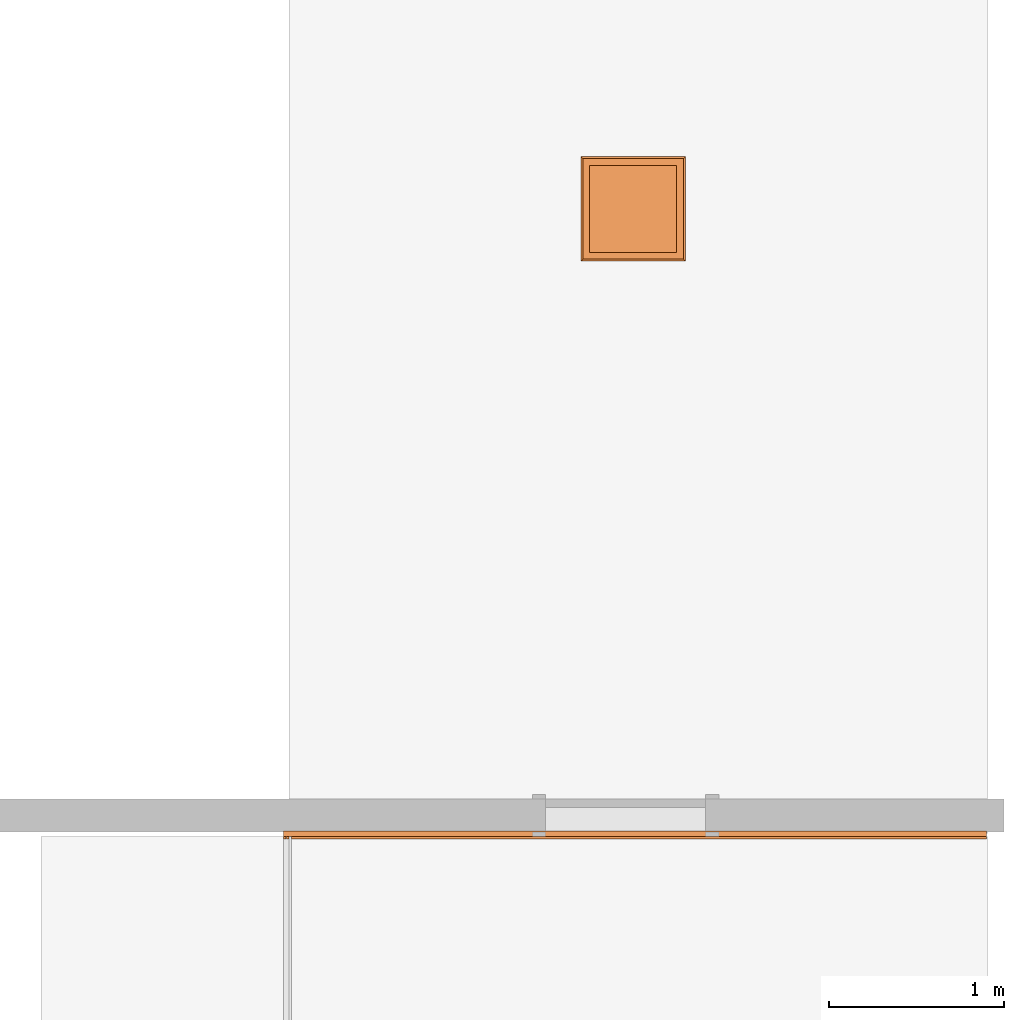
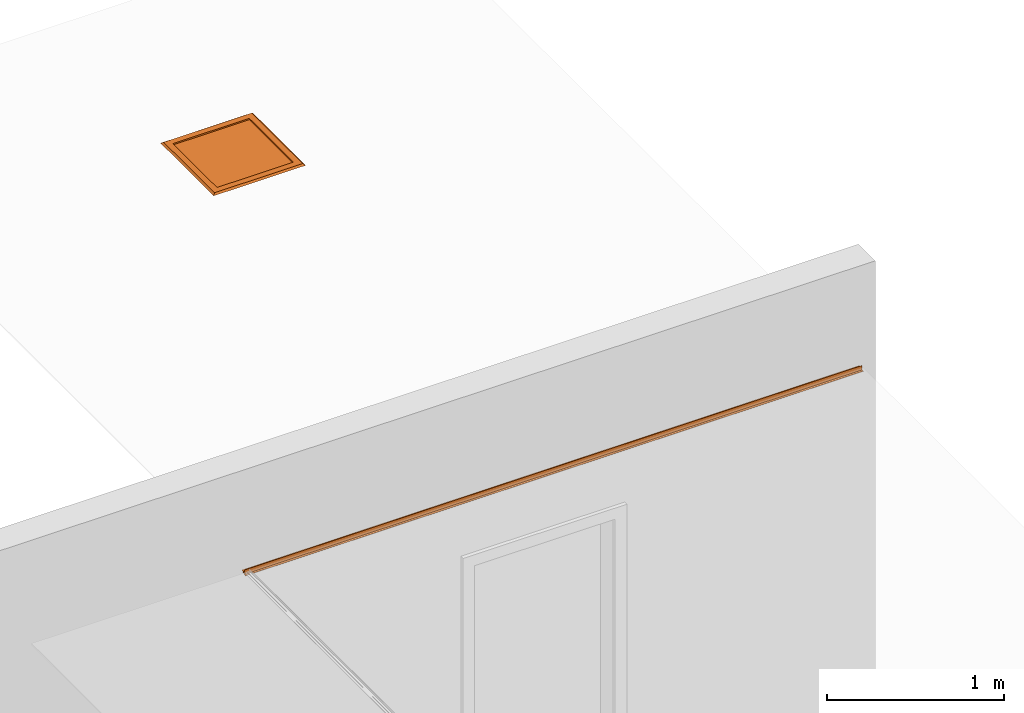
# One storey, part 4 of 4: 2 proxies.
"""IFC2X3 building model written with IfcOpenShell, lengths in millimetres."""

from ifc_helpers import new_model, entity, si_unit, converted_unit, derived_unit, direction, frame, origin, place, context, subcontext, project, spatial, faceted_brep, source, transform, mapped, material, type_object, type_shapes, element, save


model = new_model("IFC2X3")

# Units and contexts
model_context = context("Model", 3, precision=0.01, world=origin(), true_north=direction((6.12303176911189e-17, 1.0)))
body_context = subcontext(model_context, "Body", "Model", "MODEL_VIEW")
ifc_project = project(units=[si_unit("LENGTHUNIT", "METRE", prefix="MILLI"), si_unit("AREAUNIT", "SQUARE_METRE"), si_unit("VOLUMEUNIT", "CUBIC_METRE"), converted_unit("PLANEANGLEUNIT", "DEGREE", entity("IfcRatioMeasure", 0.0174532925199433), si_unit("PLANEANGLEUNIT", "RADIAN"), dimensions=[0, 0, 0, 0, 0, 0, 0]), si_unit("MASSUNIT", "GRAM", prefix="KILO"), derived_unit("MASSDENSITYUNIT", [(si_unit("MASSUNIT", "GRAM", prefix="KILO"), 1), (si_unit("LENGTHUNIT", "METRE"), -3)]), si_unit("TIMEUNIT", "SECOND"), si_unit("FREQUENCYUNIT", "HERTZ"), si_unit("THERMODYNAMICTEMPERATUREUNIT", "DEGREE_CELSIUS"), derived_unit("THERMALTRANSMITTANCEUNIT", [(si_unit("MASSUNIT", "GRAM", prefix="KILO"), 1), (si_unit("THERMODYNAMICTEMPERATUREUNIT", "KELVIN"), -1), (si_unit("TIMEUNIT", "SECOND"), -3)]), derived_unit("VOLUMETRICFLOWRATEUNIT", [(si_unit("LENGTHUNIT", "METRE"), 3), (si_unit("TIMEUNIT", "SECOND"), -1)]), si_unit("ELECTRICCURRENTUNIT", "AMPERE"), si_unit("ELECTRICVOLTAGEUNIT", "VOLT"), si_unit("POWERUNIT", "WATT"), si_unit("FORCEUNIT", "NEWTON", prefix="KILO"), si_unit("ILLUMINANCEUNIT", "LUX"), si_unit("LUMINOUSFLUXUNIT", "LUMEN"), si_unit("LUMINOUSINTENSITYUNIT", "CANDELA"), derived_unit("USERDEFINED", [(si_unit("MASSUNIT", "GRAM", prefix="KILO"), -1), (si_unit("LENGTHUNIT", "METRE"), -2), (si_unit("TIMEUNIT", "SECOND"), 3), (si_unit("LUMINOUSFLUXUNIT", "LUMEN"), 1)]), derived_unit("LINEARVELOCITYUNIT", [(si_unit("LENGTHUNIT", "METRE"), 1), (si_unit("TIMEUNIT", "SECOND"), -1)]), si_unit("PRESSUREUNIT", "PASCAL"), derived_unit("USERDEFINED", [(si_unit("LENGTHUNIT", "METRE"), -2), (si_unit("MASSUNIT", "GRAM", prefix="KILO"), 1), (si_unit("TIMEUNIT", "SECOND"), -2)])], contexts=[model_context])

# Site, building, storey
site_placement = place(None, origin())
site = spatial("IfcSite", under=ifc_project, at=site_placement, CompositionType="ELEMENT")
building_placement = place(site_placement, origin())
building = spatial("IfcBuilding", under=site, at=building_placement, CompositionType="ELEMENT")
storey_placement = place(building_placement, origin())
storey = spatial("IfcBuildingStorey", under=building, at=storey_placement, Name="Base Level", CompositionType="ELEMENT", Elevation=0.0)

# Proxies
building_element_proxy_type_1 = type_object("IfcBuildingElementProxyType", Name="Plaster Ceiling Junction", PredefinedType="NOTDEFINED")
shared_shape_1 = source(origin(), body_context, "Body", "Brep", [
    faceted_brep([(4025.0, 16.0, 31.0), (4025.0, 15.0, 31.0), (4025.0, 15.0, 1.0), (4025.0, 0.0, 1.0), (4025.0, 0.0, 0.0), (4025.0, 16.0, 0.0), (4025.0, 16.0, 15.0), (4025.0, 31.0, 15.0), (4025.0, 31.0, 0.0), (4025.0, 32.0, 0.0), (4025.0, 32.0, 12.0), (4025.0, 47.0, 12.0), (4025.0, 47.0, 13.0), (4025.0, 32.0, 13.0), (4025.0, 32.0, 16.0), (4025.0, 16.0, 16.0), (0.0, 16.0, 31.0), (0.0, 16.0, 16.0), (0.0, 32.0, 16.0), (0.0, 32.0, 13.0), (0.0, 47.0, 13.0), (0.0, 47.0, 12.0), (0.0, 32.0, 12.0), (0.0, 32.0, 0.0), (0.0, 31.0, 0.0), (0.0, 31.0, 15.0), (0.0, 16.0, 15.0), (0.0, 16.0, 0.0), (0.0, 0.0, 0.0), (0.0, 0.0, 1.0), (0.0, 15.0, 1.0), (0.0, 15.0, 12.0), (0.0, 15.0, 13.0), (0.0, 15.0, 31.0), (15.0, 15.0, 0.0), (15.0, 15.0, 1.0), (15.0, 0.0, 1.0), (15.0, 0.0, 0.0), (16.0, 15.0, 1.0), (16.0, 15.0, 0.0), (16.0, 0.0, 0.0), (16.0, 0.0, 1.0), (31.0, 15.0, 0.0), (31.0, 15.0, 1.0), (31.0, 0.0, 1.0), (31.0, 0.0, 0.0), (47.0, 15.0, 1.0), (47.0, 15.0, 0.0), (47.0, 0.0, 0.0), (47.0, 0.0, 1.0), (31.0, 15.0, 31.0), (32.0, 15.0, 31.0)], [[[0, 1, 2, 3, 4, 5, 6, 7, 8, 9, 10, 11, 12, 13, 14, 15]], [[16, 17, 18, 19, 20, 21, 22, 23, 24, 25, 26, 27, 28, 29, 30, 31, 32, 33]], [[34, 35, 36, 37]], [[38, 39, 40, 41]], [[42, 43, 44, 45]], [[46, 47, 48, 49]], [[33, 50, 51, 1, 0, 16]], [[0, 15, 17, 16]], [[15, 14, 18, 17]], [[14, 13, 19, 18]], [[13, 12, 20, 19]], [[12, 11, 21, 20]], [[11, 10, 22, 21]], [[10, 9, 23, 22]], [[9, 8, 24, 23]], [[8, 7, 25, 24]], [[7, 6, 26, 25]], [[6, 5, 27, 26]], [[5, 4, 48, 47, 42, 45, 40, 39, 34, 37, 28, 27]], [[4, 3, 49, 48]], [[3, 2, 46, 49]], [[2, 1, 51, 50, 33, 32, 31, 30, 35, 34, 39, 38, 43, 42, 47, 46]], [[40, 45, 44, 41]], [[29, 28, 37, 36]], [[41, 44, 43, 38]], [[30, 29, 36, 35]]]),
])
type_shapes(building_element_proxy_type_1, [shared_shape_1])
proxy_1_placement = place(building_placement, frame((202935.734552934, 42176.9193803934, 2599.0)))
element("IfcBuildingElementProxy", 1, at=proxy_1_placement, inside=storey, type_object=building_element_proxy_type_1, Name="TR14:Plaster Ceiling Junction:2492", ObjectType="TR14:Plaster Ceiling Junction", context=body_context, shape_type="MappedRepresentation", body=[
    mapped(shared_shape_1, transform((0.0, 0.0, 0.0), scale=1.0)),
])
ifc_material = material(Name="mesh")
building_element_proxy_type_2 = type_object("IfcBuildingElementProxyType", Name="Outer Frame", PredefinedType="NOTDEFINED", material=ifc_material)
shared_shape_2 = source(origin(), body_context, "Body", "Brep", [
    faceted_brep([(50.8000000000231, 50.8000000000144, 17.8250000000393), (50.8000000000231, 548.800000000014, 17.8250000000393), (548.800000000049, 548.800000000005, 17.8250000000393), (548.800000000049, 50.8000000000058, 17.8250000000393), (44.4500000000115, 44.4500000000202, 17.8250000000393), (555.150000000025, 44.4500000000029, 17.8250000000393), (555.15000000006, 555.149999999999, 17.8250000000393), (44.4500000000115, 555.150000000008, 17.8250000000393), (50.8000000000231, 50.8000000000144, 6.34999999999964), (548.800000000049, 50.8000000000058, 6.34999999999964), (548.800000000049, 548.800000000005, 6.34999999999964), (50.8000000000231, 548.800000000014, 6.34999999999964), (44.4500000000115, 44.4500000000202, 6.34999999999964), (44.4500000000115, 555.150000000008, 6.34999999999964), (555.15000000006, 555.149999999999, 6.34999999999964), (555.150000000025, 44.4500000000029, 6.34999999999964), (44.4500000000115, 555.150000000008, 15.3499999999998), (44.4500000000115, 44.4500000000202, 15.3499999999998), (555.150000000025, 555.149999999991, 15.3499999999998), (555.150000000025, 44.4500000000029, 15.3499999999998)], [[[0, 1, 2, 3], [4, 5, 6, 7]], [[8, 9, 10, 11], [12, 13, 14, 15]], [[3, 9, 8, 0]], [[2, 10, 9, 3]], [[1, 11, 10, 2]], [[0, 8, 11, 1]], [[7, 16, 13, 12, 17, 4]], [[6, 18, 14, 13, 16, 7]], [[5, 19, 15, 14, 18, 6]], [[4, 17, 12, 15, 19, 5]]], outer=[[False, True], [False, True], [True], [True], [True], [True], [True], [True], [True], [True]]),
    faceted_brep([(50.8000000000231, 50.8000000000144, 6.34999999999964), (50.8000000000231, 548.800000000014, 6.34999999999964), (548.800000000049, 548.800000000005, 6.34999999999964), (548.800000000014, 50.8000000000058, 6.34999999999964), (50.8000000000231, 50.8000000000144, 17.8250000000393), (548.800000000014, 50.8000000000058, 17.8250000000393), (548.800000000049, 548.800000000005, 17.8250000000393), (50.8000000000231, 548.800000000014, 17.8250000000393)], [[[0, 1, 2, 3]], [[4, 5, 6, 7]], [[7, 1, 0, 4]], [[6, 2, 1, 7]], [[5, 3, 2, 6]], [[4, 0, 3, 5]]]),
    faceted_brep([(50.8000000000231, 50.8000000000231, 27.3499999999905), (548.800000000014, 50.8000000000144, 27.3499999999905), (548.800000000014, 50.8000000000144, 17.8250000000393), (50.8000000000231, 50.8000000000231, 17.8250000000393), (548.800000000014, 548.799999999988, 27.3499999999905), (548.800000000014, 548.799999999988, 17.8250000000393), (50.8000000000231, 548.799999999997, 27.3499999999905), (50.8000000000231, 548.799999999997, 17.8250000000393), (599.600000000002, 0.0, 17.8250000000393), (0.0, 0.0, 17.8250000000393), (0.0, 599.60000000002, 17.8250000000393), (599.600000000002, 599.600000000002, 17.8250000000393), (12.7000000000231, 12.7000000000144, 27.3499999999905), (586.900000000014, 12.6999999999971, 27.3499999999905), (586.900000000014, 586.899999999997, 27.3499999999905), (12.7000000000231, 586.900000000014, 27.3499999999905)], [[[0, 1, 2, 3]], [[1, 4, 5, 2]], [[4, 6, 7, 5]], [[3, 2, 5, 7], [8, 9, 10, 11]], [[1, 0, 6, 4], [12, 13, 14, 15]], [[6, 0, 3, 7]], [[9, 8, 13, 12]], [[8, 11, 14, 13]], [[11, 10, 15, 14]], [[10, 9, 12, 15]]], outer=[[True], [True], [True], [False, True], [False, True], [True], [True], [True], [True], [True]]),
    faceted_brep([(150.459258262891, 479.861809548979, 6.34999999999964), (150.8, 482.449999999999, 6.34999999999964), (150.459258262891, 485.038190451026, 6.34999999999964), (149.460254037859, 487.449999999997, 6.34999999999964), (147.87106781188, 489.521067811868, 6.34999999999964), (145.800000000019, 491.110254037846, 6.34999999999964), (143.388190451013, 492.109258262896, 6.34999999999964), (140.800000000003, 492.450000000005, 6.34999999999964), (138.211809548992, 492.109258262896, 6.34999999999964), (135.799999999986, 491.110254037846, 6.34999999999964), (133.728932188125, 489.521067811868, 6.34999999999964), (132.139745962146, 487.449999999997, 6.34999999999964), (131.140741737114, 485.038190451026, 6.34999999999964), (130.800000000005, 482.449999999999, 6.34999999999964), (131.140741737114, 479.861809548979, 6.34999999999964), (132.139745962146, 477.45, 6.34999999999964), (133.728932188125, 475.378932188138, 6.34999999999964), (135.799999999986, 473.78974596216, 6.34999999999964), (138.211809548992, 472.79074173711, 6.34999999999964), (140.800000000003, 472.450000000001, 6.34999999999964), (143.388190451013, 472.79074173711, 6.34999999999964), (145.800000000019, 473.78974596216, 6.34999999999964), (147.87106781188, 475.378932188138, 6.34999999999964), (149.460254037859, 477.45, 6.34999999999964), (130.800000000005, 482.449999999999, 0.0), (131.140741737114, 485.038190451026, 0.0), (132.139745962146, 487.449999999997, 0.0), (133.728932188125, 489.521067811868, 0.0), (135.799999999986, 491.110254037846, 0.0), (138.211809548992, 492.109258262896, 0.0), (140.800000000003, 492.450000000005, 0.0), (143.388190451013, 492.109258262896, 0.0), (145.800000000019, 491.110254037846, 0.0), (147.87106781188, 489.521067811868, 0.0), (149.460254037859, 487.449999999997, 0.0), (150.459258262891, 485.038190451026, 0.0), (150.8, 482.449999999999, 0.0), (150.459258262891, 479.861809548979, 0.0), (149.460254037859, 477.45, 0.0), (147.87106781188, 475.378932188138, 0.0), (145.800000000019, 473.78974596216, 0.0), (143.388190451013, 472.79074173711, 0.0), (140.800000000003, 472.450000000001, 0.0), (138.211809548992, 472.79074173711, 0.0), (135.799999999986, 473.78974596216, 0.0), (133.728932188125, 475.378932188138, 0.0), (132.139745962146, 477.45, 0.0), (131.140741737114, 479.861809548979, 0.0)], [[[0, 1, 2, 3, 4, 5, 6, 7, 8, 9, 10, 11, 12, 13, 14, 15, 16, 17, 18, 19, 20, 21, 22, 23]], [[24, 25, 26, 27, 28, 29, 30, 31, 32, 33, 34, 35, 36, 37, 38, 39, 40, 41, 42, 43, 44, 45, 46, 47]], [[30, 7, 6, 31]], [[31, 6, 5, 32]], [[34, 33, 4, 3]], [[4, 33, 32, 5]], [[35, 34, 3, 2]], [[35, 2, 1, 36]], [[36, 1, 0, 37]], [[37, 0, 23, 38]], [[40, 39, 22, 21]], [[22, 39, 38, 23]], [[41, 40, 21, 20]], [[41, 20, 19, 42]], [[42, 19, 18, 43]], [[43, 18, 17, 44]], [[46, 45, 16, 15]], [[16, 45, 44, 17]], [[47, 46, 15, 14]], [[47, 14, 13, 24]], [[24, 13, 12, 25]], [[25, 12, 11, 26]], [[28, 27, 10, 9]], [[10, 27, 26, 11]], [[29, 28, 9, 8]], [[29, 8, 7, 30]]]),
    faceted_brep([(468.459258262923, 479.861809548979, 6.34999999999964), (468.800000000032, 482.449999999999, 6.34999999999964), (468.459258262923, 485.038190451026, 6.34999999999964), (467.46025403789, 487.449999999997, 6.34999999999964), (465.871067811912, 489.521067811868, 6.34999999999964), (463.80000000005, 491.110254037846, 6.34999999999964), (461.388190451045, 492.109258262896, 6.34999999999964), (458.800000000034, 492.450000000005, 6.34999999999964), (456.211809549024, 492.109258262896, 6.34999999999964), (453.800000000018, 491.110254037846, 6.34999999999964), (451.728932188156, 489.521067811868, 6.34999999999964), (450.139745962178, 487.449999999997, 6.34999999999964), (449.140741737146, 485.038190451026, 6.34999999999964), (448.800000000037, 482.449999999999, 6.34999999999964), (449.140741737146, 479.861809548979, 6.34999999999964), (450.139745962178, 477.45, 6.34999999999964), (451.728932188156, 475.378932188138, 6.34999999999964), (453.800000000018, 473.78974596216, 6.34999999999964), (456.211809549024, 472.79074173711, 6.34999999999964), (458.800000000034, 472.450000000001, 6.34999999999964), (461.388190451045, 472.79074173711, 6.34999999999964), (463.80000000005, 473.78974596216, 6.34999999999964), (465.871067811912, 475.378932188138, 6.34999999999964), (467.46025403789, 477.45, 6.34999999999964), (450.139745962178, 477.45, 0.0), (449.140741737146, 479.861809548979, 0.0), (448.800000000037, 482.449999999999, 0.0), (449.140741737146, 485.038190451026, 0.0), (450.139745962178, 487.449999999997, 0.0), (451.728932188156, 489.521067811868, 0.0), (453.800000000018, 491.110254037846, 0.0), (456.211809549024, 492.109258262896, 0.0), (458.800000000034, 492.450000000005, 0.0), (461.388190451045, 492.109258262896, 0.0), (463.80000000005, 491.110254037846, 0.0), (465.871067811912, 489.521067811868, 0.0), (467.46025403789, 487.449999999997, 0.0), (468.459258262923, 485.038190451026, 0.0), (468.800000000032, 482.449999999999, 0.0), (468.459258262923, 479.861809548979, 0.0), (467.46025403789, 477.45, 0.0), (465.871067811912, 475.378932188138, 0.0), (463.80000000005, 473.78974596216, 0.0), (461.388190451045, 472.79074173711, 0.0), (458.800000000034, 472.450000000001, 0.0), (456.211809549024, 472.79074173711, 0.0), (453.800000000018, 473.78974596216, 0.0), (451.728932188156, 475.378932188138, 0.0)], [[[0, 1, 2, 3, 4, 5, 6, 7, 8, 9, 10, 11, 12, 13, 14, 15, 16, 17, 18, 19, 20, 21, 22, 23]], [[24, 25, 26, 27, 28, 29, 30, 31, 32, 33, 34, 35, 36, 37, 38, 39, 40, 41, 42, 43, 44, 45, 46, 47]], [[32, 7, 6, 33]], [[33, 6, 5, 34]], [[36, 35, 4, 3]], [[4, 35, 34, 5]], [[37, 36, 3, 2]], [[37, 2, 1, 38]], [[38, 1, 0, 39]], [[39, 0, 23, 40]], [[42, 41, 22, 21]], [[22, 41, 40, 23]], [[43, 42, 21, 20]], [[43, 20, 19, 44]], [[44, 19, 18, 45]], [[45, 18, 17, 46]], [[24, 47, 16, 15]], [[16, 47, 46, 17]], [[25, 24, 15, 14]], [[25, 14, 13, 26]], [[26, 13, 12, 27]], [[27, 12, 11, 28]], [[30, 29, 10, 9]], [[10, 29, 28, 11]], [[31, 30, 9, 8]], [[31, 8, 7, 32]]]),
])
type_shapes(building_element_proxy_type_2, [shared_shape_2])
proxy_2_placement = place(building_placement, frame((204638.171271554, 45486.4398051241, 2595.65)))
element("IfcBuildingElementProxy", 2, at=proxy_2_placement, inside=storey, type_object=building_element_proxy_type_2, material=ifc_material, Name="Outer Frame:Outer Frame:2526", ObjectType="Outer Frame:Outer Frame", context=body_context, shape_type="MappedRepresentation", body=[
    mapped(shared_shape_2, transform((0.0, 0.0, 0.0), scale=1.0)),
])

save(model, "model.ifc")
